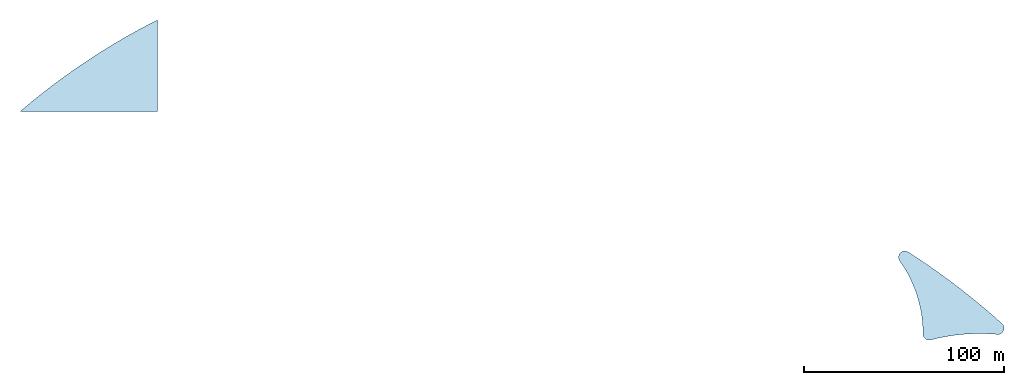
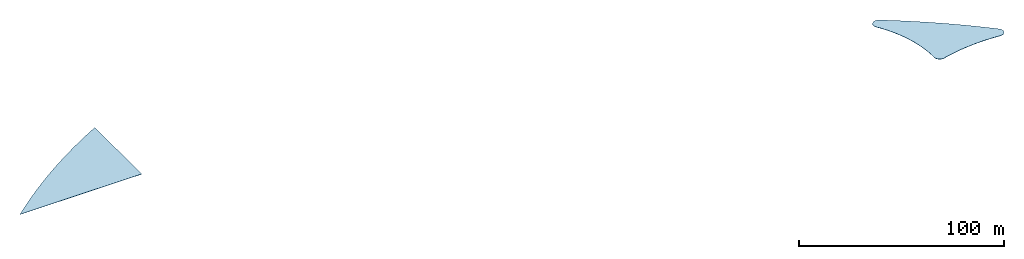
# One storey: 2 slabs, 2 elements without a shape of their own.
"""IFC2X3 building model written with IfcOpenShell, lengths in millimetres."""

from ifc_helpers import new_model, entity, si_unit, converted_unit, derived_unit, direction, frame, frame_2d, origin, place, context, subcontext, project, spatial, polyline, circle_curve, parameter, trimmed, segment, composite_curve, outline, extrude, material, layer, layer_set, element, aggregate, save


model = new_model("IFC2X3")

# Units and contexts
model_context = context("Model", 3, precision=1e-06, world=origin(), true_north=direction((2.0, 6.12303176911189e-17, 1.0)))
context_of_model = context(None, 3, precision=1e-06, world=origin(), true_north=direction((2.0, 6.12303176911189e-17, 1.0)))
body_context = subcontext(model_context, "Body", "Model", "MODEL_VIEW")
ifc_project = project(units=[si_unit("LENGTHUNIT", "METRE", prefix="MILLI"), si_unit("AREAUNIT", "SQUARE_METRE", prefix="MILLI"), si_unit("VOLUMEUNIT", "CUBIC_METRE", prefix="MILLI"), converted_unit("PLANEANGLEUNIT", "DEGREE", entity("IfcRatioMeasure", 0.0174532925199433), si_unit("PLANEANGLEUNIT", "RADIAN"), dimensions=[0, 0, 0, 0, 0, 0, 0]), si_unit("MASSUNIT", "GRAM", prefix="KILO"), si_unit("TIMEUNIT", "SECOND"), si_unit("THERMODYNAMICTEMPERATUREUNIT", "KELVIN"), derived_unit("THERMALTRANSMITTANCEUNIT", [(si_unit("MASSUNIT", "GRAM", prefix="KILO"), 1), (si_unit("THERMODYNAMICTEMPERATUREUNIT", "KELVIN"), -1), (si_unit("TIMEUNIT", "SECOND"), -3)]), derived_unit("VOLUMETRICFLOWRATEUNIT", [(si_unit("LENGTHUNIT", "METRE"), 3), (si_unit("TIMEUNIT", "SECOND"), -1)])], contexts=[model_context, context_of_model])

# Site, building, storey
site_placement = place(None, origin())
site = spatial("IfcSite", under=ifc_project, at=site_placement, CompositionType="ELEMENT")
building_placement = place(site_placement, origin())
building = spatial("IfcBuilding", under=site, at=building_placement, CompositionType="ELEMENT")
storey_placement = place(building_placement, frame((0.0, 0.0, 12000.0)))
storey = spatial("IfcBuildingStorey", under=building, at=storey_placement, Name="Level 4", CompositionType="ELEMENT", Elevation=12000.0)

# Roof, slab
roof_1_placement = place(storey_placement, origin())
roof_1 = element("IfcRoof", 1, at=roof_1_placement, inside=storey, Name="Basic Roof:Generic - 400mm", ObjectType="Basic Roof:Generic - 400mm", ShapeType="NOTDEFINED")
ifc_material = material(Name="Roofing - Asphalt")
ifc_layer = layer(ifc_material, 150.0)
ifc_layer_set = layer_set([ifc_layer], Name="Basic Roof:Generic - 400mm")
slab_1_placement = place(roof_1_placement, frame((322751.593692117, 590083.105088887, 3000.0)))
slab_1 = element("IfcSlab", 2, at=slab_1_placement, material=ifc_layer_set, Name="Basic Roof:Generic - 400mm", ObjectType="Basic Roof:Generic - 400mm", PredefinedType="ROOF", context=body_context, shape_type="SweptSolid", body=[
    extrude(outline(composite_curve([segment(trimmed(circle_curve(frame_2d((-23242.5537957766, 19162.6858003049), x_axis=(-1.0, 0.0)), 3125.0), [parameter(237.350329244166)], [parameter(35.4314354354935)], True, "PARAMETER"), True, "CONTINUOUS"), segment(trimmed(circle_curve(frame_2d((-76918.1526231916, -19026.9163908465), x_axis=(-1.0, 0.0)), 62750.0), [parameter(179.881912441281)], [parameter(215.431435435495)], True, "PARAMETER"), False, "CONTINUOUS"), segment(trimmed(circle_curve(frame_2d((-11043.2925347206, -19162.685770189), x_axis=(-1.0, 0.0)), 3125.0), [parameter(359.88191244128)], [parameter(104.726261743838)], True, "PARAMETER"), True, "CONTINUOUS"), segment(trimmed(circle_curve(frame_2d((14215.2775356054, -115263.149806484), x_axis=(-1.0, 0.0)), 96239.453150957), [parameter(264.787481627073)], [parameter(284.726261743839)], True, "PARAMETER"), False, "CONTINUOUS"), segment(trimmed(circle_curve(frame_2d((23242.5545643602, -16309.6111156676), x_axis=(-1.0, 0.0)), 3125.0), [parameter(84.7874816270833)], [parameter(227.955927531124)], True, "PARAMETER"), True, "CONTINUOUS"), segment(trimmed(circle_curve(frame_2d((-215858.08727523, -281447.352077187), x_axis=(-1.0, 0.0)), 360150.40331226), [parameter(227.955927531122)], [parameter(237.350329244166)], True, "PARAMETER"), True, "CONTINUOUS")], self_intersect=False)), frame((26367.4366596886, 22287.6523526425, 0.0)), (0.0, 0.0, 1.0), 149.999999999998),
])
aggregate(roof_1, [slab_1])

roof_2_placement = place(storey_placement, origin())
roof_2 = element("IfcRoof", 3, at=roof_2_placement, inside=storey, Name="Basic Roof:Generic - 400mm", ObjectType="Basic Roof:Generic - 400mm", ShapeType="NOTDEFINED")
slab_2_placement = place(roof_2_placement, frame((-116812.552666683, 704455.779317679, 0.0)))
slab_2 = element("IfcSlab", 4, at=slab_2_placement, material=ifc_layer_set, Name="Basic Roof:Generic - 400mm", ObjectType="Basic Roof:Generic - 400mm", PredefinedType="ROOF", context=body_context, shape_type="SweptSolid", body=[
    extrude(outline(composite_curve([segment(polyline([(-34341.5193595008, -22896.7462824665), (34341.5193594971, -22896.7462824667)]), True, "CONTINUOUS"), segment(polyline([(34341.5193594971, -22896.7462824667), (34341.5193594972, 22896.7462824646)]), True, "CONTINUOUS"), segment(trimmed(circle_curve(frame_2d((190879.785882563, -286289.666721907), x_axis=(1.0, 0.0)), 346555.1426145), [parameter(116.852678480416)], [parameter(130.533000750721)], True, "PARAMETER"), True, "CONTINUOUS")], self_intersect=False)), frame((34341.5193595008, 22896.7462824667, 0.0)), (0.0, 0.0, 1.0), 150.000000000001),
])
aggregate(roof_2, [slab_2])

save(model, "model.ifc")
